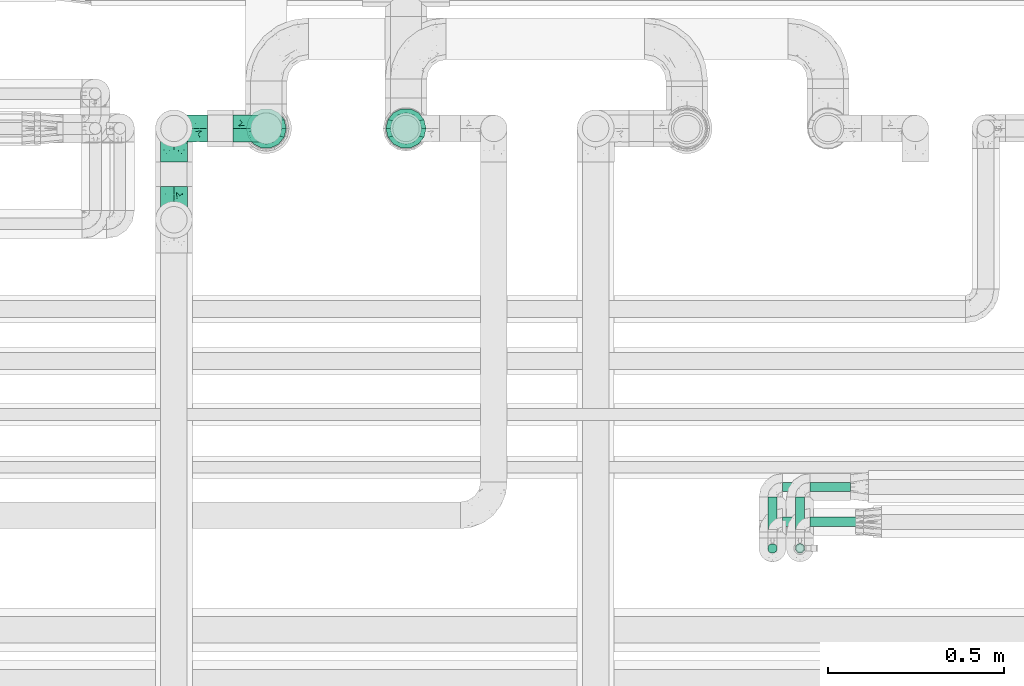
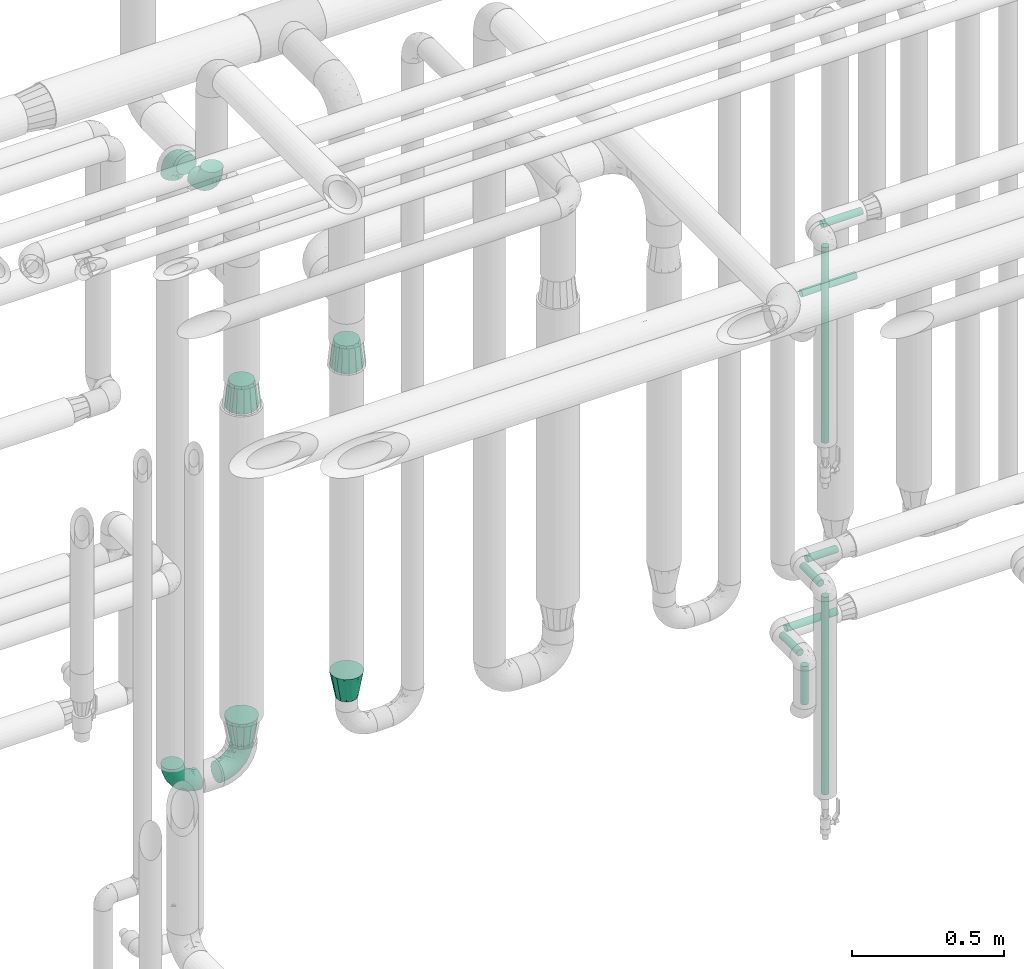
# One storey, part 706 of 824: 9 flow segments, 8 flow fittings.
"""IFC2X3 building model written with IfcOpenShell, lengths in millimetres."""

from ifc_helpers import new_model, entity, si_unit, converted_unit, derived_unit, direction, frame, origin, origin_2d_with_axis, place, context, subcontext, project, spatial, circle, extrude, faceted_brep, source, transform, mapped, material, type_object, type_shapes, element, save


model = new_model("IFC2X3")

# Units and contexts
model_context = context("Model", 3, precision=0.01, world=origin(), true_north=direction((6.12303176911189e-17, 1.0)))
body_context = subcontext(model_context, "Body", "Model", "MODEL_VIEW")
ifc_project = project(units=[si_unit("LENGTHUNIT", "METRE", prefix="MILLI"), si_unit("AREAUNIT", "SQUARE_METRE"), si_unit("VOLUMEUNIT", "CUBIC_METRE"), converted_unit("PLANEANGLEUNIT", "DEGREE", entity("IfcRatioMeasure", 0.0174532925199433), si_unit("PLANEANGLEUNIT", "RADIAN"), dimensions=[0, 0, 0, 0, 0, 0, 0]), si_unit("MASSUNIT", "GRAM", prefix="KILO"), derived_unit("MASSDENSITYUNIT", [(si_unit("MASSUNIT", "GRAM", prefix="KILO"), 1), (si_unit("LENGTHUNIT", "METRE"), -3)]), derived_unit("MOMENTOFINERTIAUNIT", [(si_unit("LENGTHUNIT", "METRE"), 4)]), si_unit("TIMEUNIT", "SECOND"), si_unit("FREQUENCYUNIT", "HERTZ"), si_unit("THERMODYNAMICTEMPERATUREUNIT", "DEGREE_CELSIUS"), derived_unit("THERMALTRANSMITTANCEUNIT", [(si_unit("MASSUNIT", "GRAM", prefix="KILO"), 1), (si_unit("THERMODYNAMICTEMPERATUREUNIT", "KELVIN"), -1), (si_unit("TIMEUNIT", "SECOND"), -3)]), derived_unit("VOLUMETRICFLOWRATEUNIT", [(si_unit("LENGTHUNIT", "METRE"), 3), (si_unit("TIMEUNIT", "SECOND"), -1)]), derived_unit("MASSFLOWRATEUNIT", [(si_unit("MASSUNIT", "GRAM", prefix="KILO"), 1), (si_unit("TIMEUNIT", "SECOND"), -1)]), derived_unit("ROTATIONALFREQUENCYUNIT", [(si_unit("TIMEUNIT", "SECOND"), -1)]), si_unit("ELECTRICCURRENTUNIT", "AMPERE"), si_unit("ELECTRICVOLTAGEUNIT", "VOLT"), si_unit("POWERUNIT", "WATT"), si_unit("FORCEUNIT", "NEWTON", prefix="KILO"), si_unit("ILLUMINANCEUNIT", "LUX"), si_unit("LUMINOUSFLUXUNIT", "LUMEN"), si_unit("LUMINOUSINTENSITYUNIT", "CANDELA"), derived_unit("USERDEFINED", [(si_unit("MASSUNIT", "GRAM", prefix="KILO"), -1), (si_unit("LENGTHUNIT", "METRE"), -2), (si_unit("TIMEUNIT", "SECOND"), 3), (si_unit("LUMINOUSFLUXUNIT", "LUMEN"), 1)]), derived_unit("LINEARVELOCITYUNIT", [(si_unit("LENGTHUNIT", "METRE"), 1), (si_unit("TIMEUNIT", "SECOND"), -1)]), si_unit("PRESSUREUNIT", "PASCAL"), derived_unit("USERDEFINED", [(si_unit("LENGTHUNIT", "METRE"), -2), (si_unit("MASSUNIT", "GRAM", prefix="KILO"), 1), (si_unit("TIMEUNIT", "SECOND"), -2)]), derived_unit("LINEARFORCEUNIT", [(si_unit("MASSUNIT", "GRAM", prefix="KILO"), 1), (si_unit("LENGTHUNIT", "METRE"), 1), (si_unit("TIMEUNIT", "SECOND"), -2), (si_unit("LENGTHUNIT", "METRE"), -1)]), derived_unit("PLANARFORCEUNIT", [(si_unit("MASSUNIT", "GRAM", prefix="KILO"), 1), (si_unit("LENGTHUNIT", "METRE"), 1), (si_unit("TIMEUNIT", "SECOND"), -2), (si_unit("LENGTHUNIT", "METRE"), -2)])], contexts=[model_context])

# Site, building, storey
site_placement = place(None, origin())
site = spatial("IfcSite", under=ifc_project, at=site_placement, CompositionType="ELEMENT")
building_placement = place(site_placement, origin())
building = spatial("IfcBuilding", under=site, at=building_placement, CompositionType="ELEMENT")
storey_placement = place(building_placement, frame((0.0, 0.0, 28200.0)))
storey = spatial("IfcBuildingStorey", under=building, at=storey_placement, CompositionType="ELEMENT", Elevation=28200.0)

# Flow segments
pipe_segment_type = type_object("IfcPipeSegmentType", PredefinedType="NOTDEFINED")
flow_segment_1_placement = place(storey_placement, frame((58598.69, 16364.84, 2635.0)))
element("IfcFlowSegment", 1, at=flow_segment_1_placement, inside=storey, type_object=pipe_segment_type, context=body_context, shape_type="SweptSolid", body=[
    extrude(circle(Radius=13.4, at=origin_2d_with_axis()), frame((0.0, 15.0, 15.0), z_axis=(1.0, 0.0, 0.0), x_axis=(0.0, 1.0, 0.0)), (0.0, 0.0, 1.0), 151.411857725938),
])
flow_segment_2_placement = place(storey_placement, frame((58554.6, 16289.84, 1836.7)))
element("IfcFlowSegment", 2, at=flow_segment_2_placement, inside=storey, type_object=pipe_segment_type, context=body_context, shape_type="SweptSolid", body=[
    extrude(circle(Radius=13.4, at=origin_2d_with_axis()), frame((15.0, 15.0, 0.0)), (0.0, 0.0, 1.0), 784.200205145647),
])
flow_segment_3_placement = place(storey_placement, frame((58554.6, 16333.95, 1235.0)))
element("IfcFlowSegment", 3, at=flow_segment_3_placement, inside=storey, type_object=pipe_segment_type, context=body_context, shape_type="SweptSolid", body=[
    extrude(circle(Radius=13.4, at=origin_2d_with_axis()), frame((15.0, 0.0, 15.0), z_axis=(0.0, 1.0, 0.0), x_axis=(1.0, 0.0, 0.0)), (0.0, 0.0, 1.0), 116.174999999997),
])
flow_segment_4_placement = place(storey_placement, frame((58554.6, 16289.85, 429.0)))
element("IfcFlowSegment", 4, at=flow_segment_4_placement, inside=storey, type_object=pipe_segment_type, context=body_context, shape_type="SweptSolid", body=[
    extrude(circle(Radius=13.4, at=origin_2d_with_axis()), frame((15.0, 15.0, 0.0)), (0.0, 0.0, 1.0), 791.899999709113),
])
flow_segment_5_placement = place(storey_placement, frame((58598.69, 16464.23, 1235.0)))
element("IfcFlowSegment", 5, at=flow_segment_5_placement, inside=storey, type_object=pipe_segment_type, context=body_context, shape_type="SweptSolid", body=[
    extrude(circle(Radius=13.4, at=origin_2d_with_axis()), frame((0.0, 15.0, 15.0), z_axis=(1.0, 0.0, 0.0), x_axis=(0.0, -1.0, 0.0)), (0.0, 0.0, 1.0), 114.325940465235),
])
flow_segment_6_placement = place(storey_placement, frame((58476.2, 16333.49, 985.0)))
element("IfcFlowSegment", 6, at=flow_segment_6_placement, inside=storey, type_object=pipe_segment_type, context=body_context, shape_type="SweptSolid", body=[
    extrude(circle(Radius=13.4, at=origin_2d_with_axis()), frame((15.0, 0.0, 15.0), z_axis=(0.0, 1.0, 0.0), x_axis=(1.0, 0.0, 0.0)), (0.0, 0.0, 1.0), 116.636658406557),
])
flow_segment_7_placement = place(storey_placement, frame((58476.2, 16289.39, 817.55)))
element("IfcFlowSegment", 7, at=flow_segment_7_placement, inside=storey, type_object=pipe_segment_type, context=body_context, shape_type="SweptSolid", body=[
    extrude(circle(Radius=13.4, at=origin_2d_with_axis()), frame((15.0, 15.0, 0.0)), (0.0, 0.0, 1.0), 153.34576210052),
])
flow_segment_8_placement = place(storey_placement, frame((58520.29, 16464.19, 985.0)))
element("IfcFlowSegment", 8, at=flow_segment_8_placement, inside=storey, type_object=pipe_segment_type, context=body_context, shape_type="SweptSolid", body=[
    extrude(circle(Radius=13.4, at=origin_2d_with_axis()), frame((0.0, 15.03, 15.0), z_axis=(0.999999985627903, -0.000169541125269406, 0.0), x_axis=(-0.000169541125269406, -0.999999985627903, 0.0)), (0.0, 0.0, 1.0), 192.725953702304),
])
flow_segment_9_placement = place(storey_placement, frame((58520.29, 16364.84, 2385.0)))
element("IfcFlowSegment", 9, at=flow_segment_9_placement, inside=storey, type_object=pipe_segment_type, context=body_context, shape_type="SweptSolid", body=[
    extrude(circle(Radius=13.4, at=origin_2d_with_axis()), frame((0.0, 15.0, 15.0), z_axis=(1.0, 0.0, 0.0), x_axis=(0.0, 1.0, 0.0)), (0.0, 0.0, 1.0), 207.529319801584),
])

# Flow fittings
ifc_material = material()
pipe_fitting_type_1 = type_object("IfcPipeFittingType", PredefinedType="NOTDEFINED", material=ifc_material)
shared_shape_1 = source(origin(), body_context, "Body", "Brep", [
    faceted_brep([(-95.0, 19.02, -32.95), (-95.0, 9.85, -36.75), (-95.0, 0.0, -38.05), (-95.0, -9.85, -36.75), (-95.0, -19.03, -32.95), (-95.0, -26.91, -26.91), (-95.0, -32.95, -19.03), (-95.0, -36.75, -9.85), (-95.0, -38.05, 0.0), (-95.0, -36.75, 9.85), (-95.0, -32.95, 19.02), (-95.0, -26.91, 26.91), (-95.0, -19.03, 32.95), (-95.0, -9.85, 36.75), (-95.0, 0.0, 38.05), (-95.0, 9.85, 36.75), (-95.0, 19.02, 32.95), (-95.0, 26.91, 26.91), (-95.0, 32.95, 19.02), (-95.0, 36.75, 9.85), (-95.0, 38.05, 0.0), (-95.0, 36.75, -9.85), (-95.0, 32.95, -19.03), (-95.0, 26.91, -26.91), (0.0, 95.0, -38.05), (-9.85, 95.0, -36.75), (-19.02, 95.0, -32.95), (-26.91, 95.0, -26.91), (-32.95, 95.0, -19.03), (-36.75, 95.0, -9.85), (-38.05, 95.0, 0.0), (-36.75, 95.0, 9.85), (-32.95, 95.0, 19.02), (-26.91, 95.0, 26.91), (-19.02, 95.0, 32.95), (-9.85, 95.0, 36.75), (0.0, 95.0, 38.05), (9.85, 95.0, 36.75), (19.03, 95.0, 32.95), (26.91, 95.0, 26.91), (32.95, 95.0, 19.02), (36.75, 95.0, 9.85), (38.05, 95.0, 0.0), (36.75, 95.0, -9.85), (32.95, 95.0, -19.03), (26.91, 95.0, -26.91), (19.03, 95.0, -32.95), (9.85, 95.0, -36.75), (-7.99, -4.96, 6.3), (-0.92, 0.92, 0.0), (4.62, 8.1, 8.01), (-76.19, -35.57, 0.0), (-64.32, -32.32, 12.43), (20.51, 62.45, 28.68), (-60.56, -33.52, 0.0), (-70.4, -13.47, 34.42), (-39.61, -5.88, 32.32), (-49.6, 2.07, 37.1), (-70.34, -28.81, 21.71), (14.64, 40.81, 26.5), (5.88, 39.61, 32.32), (3.59, 20.77, 25.31), (-40.45, 68.06, 16.75), (-62.45, -20.51, 28.68), (-44.52, -26.87, 0.0), (-28.47, -20.22, 0.0), (-26.43, -17.83, 8.75), (-76.1, 39.63, 10.76), (-72.74, 37.58, 18.19), (-60.35, 46.18, 14.61), (-13.4, 13.4, 32.12), (-20.77, -3.59, 25.31), (-14.66, 81.47, 35.56), (-6.22, 71.26, 37.92), (-57.5, 42.48, 22.79), (-15.0, 34.74, 37.7), (-27.1, 12.08, 36.05), (-9.2, 28.81, 35.63), (-79.98, 23.7, 30.95), (-73.68, -4.3, 37.48), (-30.74, 21.67, 37.97), (-62.36, 47.59, 6.79), (-72.71, 32.83, 24.69), (-67.42, 7.02, 37.95), (-32.13, 75.27, 24.51), (-43.46, 51.47, 26.26), (-24.98, 73.15, 31.29), (20.59, 41.28, 19.85), (7.79, 16.09, 15.86), (-73.21, 42.39, 0.0), (-54.73, 54.73, 0.0), (-73.44, 15.79, 35.79), (-5.94, 4.32, 20.43), (28.81, 70.34, 21.71), (32.32, 64.32, 12.43), (-53.59, 26.2, 35.09), (-52.02, 19.31, 37.21), (21.38, 33.53, 10.34), (26.87, 44.52, 0.0), (-48.28, 12.14, 38.05), (4.3, 73.68, 37.48), (-44.08, -25.52, 12.79), (-41.28, -20.59, 19.85), (35.57, 76.19, 0.0), (-47.26, 54.3, 20.18), (-47.4, 61.99, 8.58), (-42.39, 73.21, 0.0), (-39.67, 78.86, 7.21), (-45.69, 36.84, 33.11), (-32.83, 50.13, 33.35), (13.47, 70.4, 34.42), (-18.25, 63.73, 36.07), (-40.63, -13.75, 27.22), (-16.63, 46.37, 37.95), (-53.47, 38.79, 28.59), (-26.07, 48.54, 36.15), (-34.51, 34.51, 36.86), (-2.07, 49.6, 37.1), (-22.79, -10.49, 19.23), (-61.73, 28.67, 31.87), (9.65, 14.7, 0.0), (20.22, 28.47, 0.0), (33.52, 60.56, 0.0), (-11.42, -5.44, 13.25), (-14.7, -9.65, 0.0), (-81.47, 14.66, -35.56), (-62.45, -20.51, -28.68), (-71.26, 6.22, -37.92), (-75.27, 32.13, -24.51), (-73.15, 24.98, -31.29), (13.47, 70.4, -34.42), (5.88, 39.61, -32.32), (-2.07, 49.6, -37.1), (-78.86, 39.67, -7.21), (-70.4, -13.47, -34.42), (-39.61, -5.88, -32.32), (-61.99, 47.4, -8.58), (32.32, 64.32, -12.43), (28.81, 70.34, -21.71), (-63.73, 18.25, -36.07), (-50.13, 32.83, -33.35), (4.3, 73.68, -37.48), (-7.02, 67.42, -37.95), (-39.63, 76.1, -10.76), (-46.18, 60.35, -14.61), (-47.59, 62.36, -6.79), (-64.32, -32.32, -12.43), (-26.2, 53.59, -35.09), (-15.79, 73.44, -35.79), (-19.31, 52.02, -37.21), (-37.58, 72.74, -18.19), (-70.34, -28.81, -21.71), (-42.48, 57.5, -22.79), (-38.79, 53.47, -28.59), (-51.47, 43.46, -26.26), (-32.83, 72.71, -24.69), (-46.37, 16.63, -37.95), (-73.68, -4.3, -37.48), (-41.28, -20.59, -19.85), (-44.08, -25.52, -12.79), (13.75, 40.63, -27.22), (20.51, 62.45, -28.68), (-68.06, 40.45, -16.75), (-54.3, 47.26, -20.18), (-12.14, 48.28, -38.05), (-21.67, 30.74, -37.97), (-36.84, 45.69, -33.11), (-11.42, -5.44, -13.25), (7.79, 16.09, -15.86), (4.62, 8.1, -8.01), (-23.7, 79.98, -30.95), (-26.43, -17.83, -8.75), (-7.99, -4.96, -6.3), (-40.81, -14.64, -26.5), (-20.77, -3.59, -25.31), (-34.74, 15.0, -37.7), (-12.08, 27.1, -36.05), (-28.81, 9.2, -35.63), (-22.79, -10.49, -19.23), (21.38, 33.53, -10.34), (20.59, 41.28, -19.85), (-48.54, 26.07, -36.15), (-49.6, 2.07, -37.1), (-13.4, 13.4, -32.12), (3.59, 20.77, -25.31), (-28.67, 61.73, -31.87), (-34.51, 34.51, -36.86), (-5.94, 4.32, -20.43)], [[[0, 1, 2, 3, 4, 5, 6, 7, 8, 9, 10, 11, 12, 13, 14, 15, 16, 17, 18, 19, 20, 21, 22, 23]], [[24, 25, 26, 27, 28, 29, 30, 31, 32, 33, 34, 35, 36, 37, 38, 39, 40, 41, 42, 43, 44, 45, 46, 47]], [[48, 49, 50]], [[51, 52, 9]], [[53, 39, 38]], [[9, 52, 10]], [[54, 52, 51]], [[55, 56, 57]], [[11, 10, 58]], [[59, 60, 61]], [[32, 31, 62]], [[63, 12, 11]], [[63, 55, 12]], [[64, 65, 66]], [[67, 68, 69]], [[70, 56, 71]], [[35, 72, 73]], [[69, 68, 74]], [[75, 76, 77]], [[16, 78, 17]], [[13, 79, 14]], [[76, 75, 80]], [[67, 69, 81]], [[18, 17, 82]], [[14, 79, 83]], [[20, 19, 67]], [[84, 85, 86]], [[87, 61, 88]], [[89, 81, 90]], [[18, 82, 68]], [[15, 91, 16]], [[14, 83, 15]], [[71, 92, 61]], [[17, 78, 82]], [[93, 87, 94]], [[95, 91, 96]], [[97, 98, 94]], [[86, 72, 34]], [[96, 99, 80]], [[37, 36, 100]], [[40, 39, 93]], [[40, 94, 41]], [[64, 66, 101]], [[93, 94, 40]], [[58, 102, 63]], [[94, 103, 41]], [[94, 87, 97]], [[104, 69, 74]], [[34, 33, 86]], [[105, 69, 104]], [[52, 58, 10]], [[106, 107, 30]], [[108, 109, 85]], [[105, 106, 90]], [[53, 110, 60]], [[86, 111, 72]], [[86, 109, 111]], [[33, 84, 86]], [[12, 55, 13]], [[112, 56, 63]], [[110, 38, 37]], [[34, 72, 35]], [[36, 35, 73]], [[111, 113, 73]], [[105, 107, 106]], [[110, 53, 38]], [[74, 114, 85]], [[91, 15, 83]], [[105, 90, 81]], [[107, 62, 31]], [[33, 32, 84]], [[115, 109, 116]], [[111, 115, 113]], [[100, 73, 117]], [[56, 55, 63]], [[79, 55, 57]], [[102, 118, 112]], [[56, 70, 76]], [[100, 110, 37]], [[117, 77, 60]], [[117, 60, 110]], [[60, 70, 61]], [[58, 52, 101]], [[63, 11, 58]], [[39, 53, 93]], [[87, 93, 53]], [[96, 91, 83]], [[78, 91, 119]], [[32, 62, 84]], [[84, 62, 104]], [[86, 85, 109]], [[85, 114, 108]], [[80, 113, 116]], [[117, 73, 113]], [[80, 116, 96]], [[80, 57, 76]], [[71, 112, 118]], [[61, 87, 59]], [[62, 107, 105]], [[97, 120, 121]], [[70, 71, 61]], [[71, 118, 92]], [[73, 100, 36]], [[110, 100, 117]], [[55, 79, 13]], [[83, 79, 57]], [[96, 83, 99]], [[116, 108, 95]], [[50, 97, 88]], [[97, 87, 88]], [[50, 49, 120]], [[122, 94, 98]], [[89, 20, 67]], [[105, 81, 69]], [[89, 67, 81]], [[68, 19, 18]], [[68, 67, 19]], [[74, 68, 82]], [[114, 82, 119]], [[74, 85, 104]], [[82, 114, 74]], [[114, 119, 108]], [[95, 108, 119]], [[116, 109, 108]], [[123, 48, 50]], [[97, 50, 120]], [[123, 50, 88]], [[91, 95, 119]], [[116, 95, 96]], [[84, 104, 85]], [[104, 62, 105]], [[83, 57, 99]], [[57, 80, 99]], [[66, 48, 123]], [[66, 124, 48]], [[118, 66, 123]], [[124, 66, 65]], [[66, 118, 101]], [[54, 64, 52]], [[124, 49, 48]], [[30, 107, 31]], [[91, 78, 16]], [[82, 78, 119]], [[56, 76, 57]], [[77, 76, 70]], [[60, 77, 70]], [[77, 117, 75]], [[117, 113, 75]], [[113, 80, 75]], [[9, 8, 51]], [[103, 94, 122]], [[103, 42, 41]], [[73, 72, 111]], [[113, 115, 116]], [[111, 109, 115]], [[102, 112, 63]], [[71, 56, 112]], [[118, 102, 101]], [[92, 123, 88]], [[123, 92, 118]], [[61, 92, 88]], [[87, 53, 59]], [[60, 59, 53]], [[97, 121, 98]], [[58, 101, 102]], [[64, 101, 52]], [[125, 1, 0]], [[126, 5, 4]], [[2, 1, 127]], [[1, 125, 127]], [[128, 129, 23]], [[130, 131, 132]], [[89, 133, 20]], [[126, 134, 135]], [[136, 89, 90]], [[137, 138, 44]], [[139, 129, 140]], [[24, 141, 142]], [[143, 144, 145]], [[125, 129, 139]], [[6, 146, 7]], [[147, 148, 149]], [[146, 51, 7]], [[143, 150, 144]], [[146, 6, 151]], [[152, 153, 154]], [[126, 4, 134]], [[0, 23, 129]], [[28, 155, 150]], [[43, 42, 103]], [[54, 146, 64]], [[139, 156, 127]], [[157, 3, 2]], [[151, 158, 159]], [[160, 131, 161]], [[22, 21, 162]], [[136, 144, 163]], [[149, 164, 165]], [[24, 142, 25]], [[166, 140, 154]], [[154, 129, 128]], [[143, 30, 29]], [[167, 168, 169]], [[155, 28, 27]], [[26, 170, 27]], [[171, 167, 172]], [[26, 25, 148]], [[27, 170, 155]], [[173, 135, 174]], [[144, 150, 152]], [[175, 176, 177]], [[24, 47, 141]], [[45, 161, 46]], [[148, 25, 142]], [[176, 175, 165]], [[64, 159, 171]], [[138, 45, 44]], [[130, 46, 161]], [[137, 44, 43]], [[178, 159, 158]], [[137, 103, 122]], [[163, 144, 152]], [[136, 133, 89]], [[103, 137, 43]], [[6, 5, 151]], [[178, 158, 173]], [[134, 4, 3]], [[178, 173, 174]], [[137, 98, 179]], [[145, 90, 106]], [[138, 180, 161]], [[46, 130, 47]], [[136, 90, 145]], [[133, 162, 21]], [[23, 22, 128]], [[139, 140, 181]], [[139, 181, 156]], [[157, 127, 182]], [[157, 134, 3]], [[182, 177, 135]], [[182, 135, 134]], [[135, 183, 174]], [[131, 130, 161]], [[141, 130, 132]], [[160, 180, 184]], [[131, 183, 176]], [[5, 126, 151]], [[158, 151, 126]], [[180, 138, 137]], [[161, 45, 138]], [[149, 148, 142]], [[170, 148, 185]], [[22, 162, 128]], [[128, 162, 163]], [[129, 154, 140]], [[154, 153, 166]], [[165, 156, 186]], [[182, 127, 156]], [[165, 186, 149]], [[165, 132, 176]], [[131, 184, 183]], [[187, 167, 178]], [[184, 168, 187]], [[167, 169, 172]], [[184, 180, 168]], [[174, 183, 184]], [[127, 157, 2]], [[134, 157, 182]], [[130, 141, 47]], [[142, 141, 132]], [[149, 142, 164]], [[186, 166, 147]], [[180, 179, 168]], [[169, 179, 120]], [[137, 179, 180]], [[179, 121, 120]], [[106, 30, 143]], [[136, 145, 144]], [[106, 143, 145]], [[150, 29, 28]], [[150, 143, 29]], [[152, 150, 155]], [[153, 155, 185]], [[152, 154, 163]], [[155, 153, 152]], [[153, 185, 166]], [[147, 166, 185]], [[186, 140, 166]], [[169, 120, 49]], [[169, 49, 172]], [[179, 169, 168]], [[148, 147, 185]], [[186, 147, 149]], [[128, 163, 154]], [[163, 162, 136]], [[142, 132, 164]], [[132, 165, 164]], [[171, 124, 65]], [[124, 171, 172]], [[64, 146, 159]], [[171, 159, 178]], [[171, 65, 64]], [[172, 49, 124]], [[162, 133, 136]], [[20, 133, 21]], [[148, 170, 26]], [[155, 170, 185]], [[131, 176, 132]], [[177, 176, 183]], [[135, 177, 183]], [[177, 182, 175]], [[182, 156, 175]], [[156, 165, 175]], [[51, 146, 54]], [[51, 8, 7]], [[129, 125, 0]], [[127, 125, 139]], [[140, 186, 181]], [[156, 181, 186]], [[158, 126, 173]], [[135, 173, 126]], [[187, 178, 174]], [[171, 178, 167]], [[184, 187, 174]], [[167, 187, 168]], [[180, 160, 161]], [[184, 131, 160]], [[98, 137, 122]], [[98, 121, 179]], [[151, 159, 146]]]),
])
type_shapes(pipe_fitting_type_1, [shared_shape_1])
for number, where, z_axis, x_axis in (
    (10, (57050.07, 17500.0, 352.5), (0.0, -1.0, 0.0), (1.0, 0.0, 0.0)),
    (11, (56787.39, 17500.0, 352.5), (0.0, 1.0, 0.0), (-1.0, 0.0, 0.0)),
    (12, (56787.39, 17240.0, 2900.0), (1.0, 0.0, 0.0), (0.0, 0.0, -1.0)),
    (13, (56787.39, 17500.0, 2900.0), (1.0, 0.0, 0.0), (0.0, 0.0, 1.0)),
):
    element("IfcFlowFitting", number, at=place(storey_placement, frame(where, z_axis=z_axis, x_axis=x_axis)), inside=storey, type_object=pipe_fitting_type_1, material=ifc_material, context=body_context, shape_type="MappedRepresentation", body=[
        mapped(shared_shape_1, transform((0.0, 0.0, 0.0), scale=1.0)),
    ])
pipe_fitting_type_2 = type_object("IfcPipeFittingType", PredefinedType="NOTDEFINED", material=ifc_material)
shared_shape_2 = source(origin(), body_context, "Body", "Brep", [
    faceted_brep([(102.0, -57.15, 0.0), (102.0, -54.32, -12.4), (102.0, -51.49, -24.8), (102.0, -43.56, -34.74), (102.0, -35.63, -44.68), (102.0, -24.17, -50.2), (102.0, -12.72, -55.72), (102.0, 0.0, -55.72), (102.0, 12.72, -55.72), (102.0, 24.17, -50.2), (102.0, 35.63, -44.68), (102.0, 43.56, -34.74), (102.0, 51.49, -24.8), (102.0, 54.32, -12.4), (102.0, 57.15, 0.0), (102.0, 54.32, 12.4), (102.0, 51.49, 24.8), (102.0, 43.56, 34.74), (102.0, 35.63, 44.68), (102.0, 24.17, 50.2), (102.0, 12.72, 55.72), (102.0, 0.0, 55.72), (102.0, -12.72, 55.72), (102.0, -24.17, 50.2), (102.0, -35.63, 44.68), (102.0, -43.56, 34.74), (102.0, -51.49, 24.8), (102.0, -54.32, 12.4), (0.0, -38.49, -22.22), (0.0, -41.47, -11.11), (0.0, -44.45, 0.0), (0.0, -41.47, 11.11), (0.0, -38.49, 22.23), (0.0, -30.36, 30.36), (0.0, -22.23, 38.49), (0.0, -11.11, 41.47), (0.0, 0.0, 44.45), (0.0, 11.11, 41.47), (0.0, 22.23, 38.49), (0.0, 30.36, 30.36), (0.0, 38.49, 22.23), (0.0, 41.47, 11.11), (0.0, 44.45, 0.0), (0.0, 41.47, -11.11), (0.0, 38.49, -22.23), (0.0, 30.36, -30.36), (0.0, 22.22, -38.49), (0.0, 11.11, -41.47), (0.0, 0.0, -44.45), (0.0, -11.11, -41.47), (0.0, -22.23, -38.49), (0.0, -30.36, -30.36)], [[[0, 1, 2, 3, 4, 5, 6, 7, 8, 9, 10, 11, 12, 13, 14, 15, 16, 17, 18, 19, 20, 21, 22, 23, 24, 25, 26, 27]], [[28, 29, 30, 31, 32, 33, 34, 35, 36, 37, 38, 39, 40, 41, 42, 43, 44, 45, 46, 47, 48, 49, 50, 51]], [[28, 2, 29]], [[11, 10, 45]], [[11, 44, 12]], [[3, 2, 28]], [[30, 29, 1]], [[42, 13, 43]], [[30, 1, 0]], [[46, 10, 9]], [[48, 8, 7, 6]], [[28, 51, 3]], [[29, 2, 1]], [[47, 46, 9]], [[5, 4, 50]], [[51, 4, 3]], [[8, 48, 47]], [[13, 42, 14]], [[51, 50, 4]], [[8, 47, 9]], [[5, 49, 6]], [[44, 11, 45]], [[43, 12, 44]], [[10, 46, 45]], [[49, 5, 50]], [[49, 48, 6]], [[13, 12, 43]], [[40, 16, 41]], [[25, 24, 33]], [[25, 32, 26]], [[17, 16, 40]], [[42, 41, 15]], [[30, 27, 31]], [[42, 15, 14]], [[34, 24, 23]], [[36, 22, 21, 20]], [[40, 39, 17]], [[41, 16, 15]], [[35, 34, 23]], [[19, 18, 38]], [[39, 18, 17]], [[22, 36, 35]], [[27, 30, 0]], [[39, 38, 18]], [[22, 35, 23]], [[19, 37, 20]], [[32, 25, 33]], [[31, 26, 32]], [[24, 34, 33]], [[37, 19, 38]], [[37, 36, 20]], [[27, 26, 31]]]),
])
type_shapes(pipe_fitting_type_2, [shared_shape_2])
flow_fitting_1_placement = place(storey_placement, frame((57447.89, 17500.0, 1915.45), z_axis=(0.0, 1.0, 0.0), x_axis=(0.0, 0.0, -1.0)))
element("IfcFlowFitting", 14, at=flow_fitting_1_placement, inside=storey, type_object=pipe_fitting_type_2, material=ifc_material, context=body_context, shape_type="MappedRepresentation", body=[
    mapped(shared_shape_2, transform((0.0, 0.0, 0.0), scale=1.0)),
])
pipe_fitting_type_3 = type_object("IfcPipeFittingType", PredefinedType="NOTDEFINED", material=ifc_material)
shared_shape_3 = source(origin(), body_context, "Body", "Brep", [
    faceted_brep([(102.0, 38.05, 0.0), (102.0, 35.5, 9.51), (102.0, 32.95, 19.03), (102.0, 25.99, 25.99), (102.0, 19.02, 32.95), (102.0, 9.51, 35.5), (102.0, 0.0, 38.05), (102.0, -9.51, 35.5), (102.0, -19.03, 32.95), (102.0, -25.99, 25.99), (102.0, -32.95, 19.03), (102.0, -35.5, 9.51), (102.0, -38.05, 0.0), (102.0, -35.5, -9.51), (102.0, -32.95, -19.02), (102.0, -25.99, -25.99), (102.0, -19.03, -32.95), (102.0, -9.51, -35.5), (102.0, 0.0, -38.05), (102.0, 9.51, -35.5), (102.0, 19.02, -32.95), (102.0, 25.99, -25.99), (102.0, 32.95, -19.02), (102.0, 35.5, -9.51), (0.0, 43.56, 34.74), (0.0, 51.49, 24.8), (0.0, 54.32, 12.4), (0.0, 57.15, 0.0), (0.0, 54.32, -12.4), (0.0, 51.49, -24.8), (0.0, 43.56, -34.74), (0.0, 35.63, -44.68), (0.0, 24.17, -50.2), (0.0, 12.72, -55.72), (0.0, 0.0, -55.72), (0.0, -12.72, -55.72), (0.0, -24.17, -50.2), (0.0, -35.63, -44.68), (0.0, -43.56, -34.74), (0.0, -51.49, -24.8), (0.0, -54.32, -12.4), (0.0, -57.15, 0.0), (0.0, -54.32, 12.4), (0.0, -51.49, 24.8), (0.0, -43.56, 34.74), (0.0, -35.63, 44.68), (0.0, -24.17, 50.2), (0.0, -12.72, 55.72), (0.0, 0.0, 55.72), (0.0, 12.72, 55.72), (0.0, 24.17, 50.2), (0.0, 35.63, 44.68)], [[[0, 1, 2, 3, 4, 5, 6, 7, 8, 9, 10, 11, 12, 13, 14, 15, 16, 17, 18, 19, 20, 21, 22, 23]], [[24, 25, 26, 27, 28, 29, 30, 31, 32, 33, 34, 35, 36, 37, 38, 39, 40, 41, 42, 43, 44, 45, 46, 47, 48, 49, 50, 51]], [[32, 31, 20]], [[40, 12, 41]], [[30, 29, 22]], [[22, 29, 23]], [[40, 39, 13]], [[12, 40, 13]], [[37, 16, 15]], [[18, 35, 34, 33]], [[16, 37, 36]], [[32, 19, 33]], [[36, 17, 16]], [[22, 21, 30]], [[38, 14, 39]], [[23, 29, 28]], [[21, 31, 30]], [[0, 28, 27]], [[36, 35, 17]], [[0, 23, 28]], [[39, 14, 13]], [[14, 38, 15]], [[21, 20, 31]], [[19, 18, 33]], [[35, 18, 17]], [[38, 37, 15]], [[19, 32, 20]], [[46, 45, 8]], [[26, 0, 27]], [[44, 43, 10]], [[10, 43, 11]], [[26, 25, 1]], [[0, 26, 1]], [[51, 4, 3]], [[6, 49, 48, 47]], [[4, 51, 50]], [[46, 7, 47]], [[50, 5, 4]], [[10, 9, 44]], [[24, 2, 25]], [[11, 43, 42]], [[9, 45, 44]], [[12, 42, 41]], [[50, 49, 5]], [[12, 11, 42]], [[25, 2, 1]], [[2, 24, 3]], [[9, 8, 45]], [[7, 6, 47]], [[49, 6, 5]], [[24, 51, 3]], [[7, 46, 8]]]),
])
type_shapes(pipe_fitting_type_3, [shared_shape_3])
flow_fitting_2_placement = place(storey_placement, frame((57447.89, 17500.0, 589.0), z_axis=(0.0, 1.0, 0.0), x_axis=(0.0, 0.0, -1.0)))
element("IfcFlowFitting", 15, at=flow_fitting_2_placement, inside=storey, type_object=pipe_fitting_type_3, material=ifc_material, context=body_context, shape_type="MappedRepresentation", body=[
    mapped(shared_shape_3, transform((0.0, 0.0, 0.0), scale=1.0)),
])
pipe_fitting_type_4 = type_object("IfcPipeFittingType", PredefinedType="NOTDEFINED", material=ifc_material)
shared_shape_4 = source(origin(), body_context, "Body", "Brep", [
    faceted_brep([(102.0, -30.36, 30.36), (102.0, -38.49, 22.23), (102.0, -41.47, 11.11), (102.0, -44.45, 0.0), (102.0, -41.47, -11.11), (102.0, -38.49, -22.22), (102.0, -30.36, -30.36), (102.0, -22.23, -38.49), (102.0, -11.11, -41.47), (102.0, 0.0, -44.45), (102.0, 11.11, -41.47), (102.0, 22.22, -38.49), (102.0, 30.36, -30.36), (102.0, 38.49, -22.22), (102.0, 41.47, -11.11), (102.0, 44.45, 0.0), (102.0, 41.47, 11.11), (102.0, 38.49, 22.23), (102.0, 30.36, 30.36), (102.0, 22.22, 38.49), (102.0, 11.11, 41.47), (102.0, 0.0, 44.45), (102.0, -11.11, 41.47), (102.0, -22.23, 38.49), (0.0, 24.17, 50.2), (0.0, 35.63, 44.68), (0.0, 43.56, 34.74), (0.0, 51.49, 24.8), (0.0, 54.32, 12.4), (0.0, 57.15, 0.0), (0.0, 54.32, -12.4), (0.0, 51.49, -24.8), (0.0, 43.56, -34.74), (0.0, 35.63, -44.68), (0.0, 24.17, -50.2), (0.0, 12.72, -55.72), (0.0, 0.0, -55.72), (0.0, -12.72, -55.72), (0.0, -24.17, -50.2), (0.0, -35.63, -44.68), (0.0, -43.56, -34.74), (0.0, -51.49, -24.8), (0.0, -54.32, -12.4), (0.0, -57.15, 0.0), (0.0, -54.32, 12.4), (0.0, -51.49, 24.8), (0.0, -43.56, 34.74), (0.0, -35.63, 44.68), (0.0, -24.17, 50.2), (0.0, -12.72, 55.72), (0.0, 0.0, 55.72), (0.0, 12.72, 55.72)], [[[0, 1, 2, 3, 4, 5, 6, 7, 8, 9, 10, 11, 12, 13, 14, 15, 16, 17, 18, 19, 20, 21, 22, 23]], [[24, 25, 26, 27, 28, 29, 30, 31, 32, 33, 34, 35, 36, 37, 38, 39, 40, 41, 42, 43, 44, 45, 46, 47, 48, 49, 50, 51]], [[14, 31, 30]], [[42, 3, 43]], [[32, 31, 13]], [[13, 31, 14]], [[34, 10, 35]], [[3, 42, 4]], [[12, 11, 33]], [[9, 37, 36, 35]], [[7, 39, 38]], [[39, 7, 6]], [[38, 8, 7]], [[34, 33, 11]], [[10, 9, 35]], [[40, 5, 41]], [[12, 33, 32]], [[15, 30, 29]], [[38, 37, 8]], [[15, 14, 30]], [[41, 5, 4]], [[5, 40, 6]], [[13, 12, 32]], [[10, 34, 11]], [[37, 9, 8]], [[40, 39, 6]], [[42, 41, 4]], [[2, 45, 44]], [[28, 15, 29]], [[46, 45, 1]], [[1, 45, 2]], [[48, 22, 49]], [[15, 28, 16]], [[0, 23, 47]], [[21, 51, 50, 49]], [[19, 25, 24]], [[25, 19, 18]], [[24, 20, 19]], [[48, 47, 23]], [[22, 21, 49]], [[26, 17, 27]], [[0, 47, 46]], [[3, 44, 43]], [[24, 51, 20]], [[3, 2, 44]], [[27, 17, 16]], [[17, 26, 18]], [[1, 0, 46]], [[22, 48, 23]], [[51, 21, 20]], [[26, 25, 18]], [[28, 27, 16]]]),
])
type_shapes(pipe_fitting_type_4, [shared_shape_4])
flow_fitting_3_placement = place(storey_placement, frame((57050.07, 17500.0, 1790.74), z_axis=(0.0, 1.0, 0.0), x_axis=(0.0, 0.0, 1.0)))
element("IfcFlowFitting", 16, at=flow_fitting_3_placement, inside=storey, type_object=pipe_fitting_type_4, material=ifc_material, context=body_context, shape_type="MappedRepresentation", body=[
    mapped(shared_shape_4, transform((0.0, 0.0, 0.0), scale=1.0)),
])
pipe_fitting_type_5 = type_object("IfcPipeFittingType", PredefinedType="NOTDEFINED", material=ifc_material)
shared_shape_5 = source(origin(), body_context, "Body", "Brep", [
    faceted_brep([(102.0, -57.15, 0.0), (102.0, -54.32, -12.4), (102.0, -51.49, -24.8), (102.0, -43.56, -34.74), (102.0, -35.63, -44.68), (102.0, -24.17, -50.2), (102.0, -12.72, -55.72), (102.0, 0.0, -55.72), (102.0, 12.72, -55.72), (102.0, 24.17, -50.2), (102.0, 35.63, -44.68), (102.0, 43.56, -34.74), (102.0, 51.49, -24.8), (102.0, 54.32, -12.4), (102.0, 57.15, 0.0), (102.0, 54.32, 12.4), (102.0, 51.49, 24.8), (102.0, 43.56, 34.74), (102.0, 35.63, 44.68), (102.0, 24.17, 50.2), (102.0, 12.72, 55.72), (102.0, 0.0, 55.72), (102.0, -12.72, 55.72), (102.0, -24.17, 50.2), (102.0, -35.63, 44.68), (102.0, -43.56, 34.74), (102.0, -51.49, 24.8), (102.0, -54.32, 12.4), (0.0, 38.05, 0.0), (0.0, 35.5, -9.51), (0.0, 32.95, -19.02), (0.0, 25.99, -25.99), (0.0, 19.02, -32.95), (0.0, 9.51, -35.5), (0.0, 0.0, -38.05), (0.0, -9.51, -35.5), (0.0, -19.02, -32.95), (0.0, -25.99, -25.99), (0.0, -32.95, -19.02), (0.0, -35.5, -9.51), (0.0, -38.05, 0.0), (0.0, -35.5, 9.51), (0.0, -32.95, 19.03), (0.0, -25.99, 25.99), (0.0, -19.03, 32.95), (0.0, -9.51, 35.5), (0.0, 0.0, 38.05), (0.0, 9.51, 35.5), (0.0, 19.03, 32.95), (0.0, 25.99, 25.99), (0.0, 32.95, 19.03), (0.0, 35.5, 9.51)], [[[0, 1, 2, 3, 4, 5, 6, 7, 8, 9, 10, 11, 12, 13, 14, 15, 16, 17, 18, 19, 20, 21, 22, 23, 24, 25, 26, 27]], [[28, 29, 30, 31, 32, 33, 34, 35, 36, 37, 38, 39, 40, 41, 42, 43, 44, 45, 46, 47, 48, 49, 50, 51]], [[38, 2, 39]], [[11, 10, 31]], [[8, 34, 33]], [[3, 2, 38]], [[40, 39, 1]], [[28, 13, 29]], [[40, 1, 0]], [[32, 10, 9]], [[34, 8, 7, 6]], [[37, 36, 4]], [[39, 2, 1]], [[33, 32, 9]], [[38, 37, 3]], [[37, 4, 3]], [[5, 4, 36]], [[13, 28, 14]], [[10, 32, 31]], [[8, 33, 9]], [[35, 5, 36]], [[30, 11, 31]], [[29, 12, 30]], [[5, 35, 6]], [[35, 34, 6]], [[11, 30, 12]], [[13, 12, 29]], [[50, 16, 51]], [[25, 24, 43]], [[22, 46, 45]], [[17, 16, 50]], [[28, 51, 15]], [[40, 27, 41]], [[28, 15, 14]], [[44, 24, 23]], [[46, 22, 21, 20]], [[49, 48, 18]], [[51, 16, 15]], [[45, 44, 23]], [[50, 49, 17]], [[49, 18, 17]], [[19, 18, 48]], [[27, 40, 0]], [[24, 44, 43]], [[22, 45, 23]], [[47, 19, 48]], [[42, 25, 43]], [[41, 26, 42]], [[19, 47, 20]], [[47, 46, 20]], [[25, 42, 26]], [[27, 26, 41]]]),
])
type_shapes(pipe_fitting_type_5, [shared_shape_5])
flow_fitting_4_placement = place(storey_placement, frame((57050.07, 17500.0, 447.5), z_axis=(0.0, 1.0, 0.0), x_axis=(0.0, 0.0, 1.0)))
element("IfcFlowFitting", 17, at=flow_fitting_4_placement, inside=storey, type_object=pipe_fitting_type_5, material=ifc_material, context=body_context, shape_type="MappedRepresentation", body=[
    mapped(shared_shape_5, transform((0.0, 0.0, 0.0), scale=1.0)),
])

save(model, "model.ifc")
